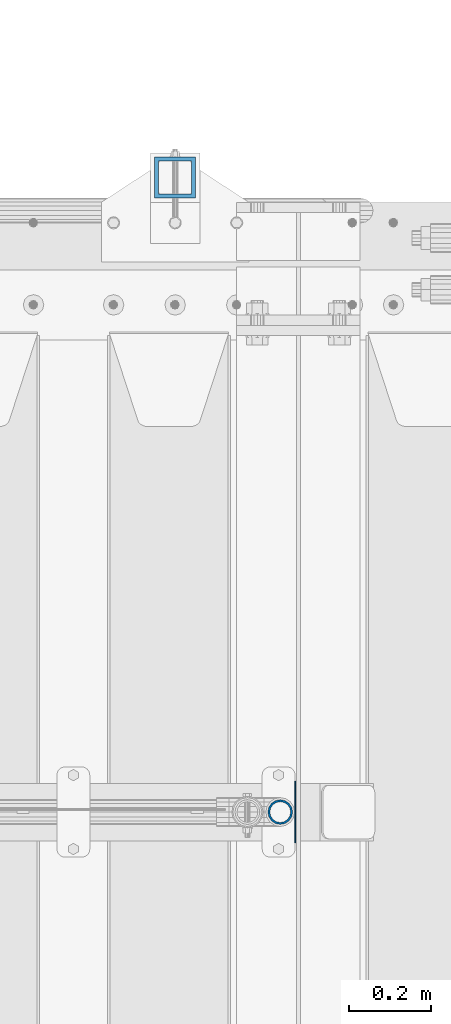
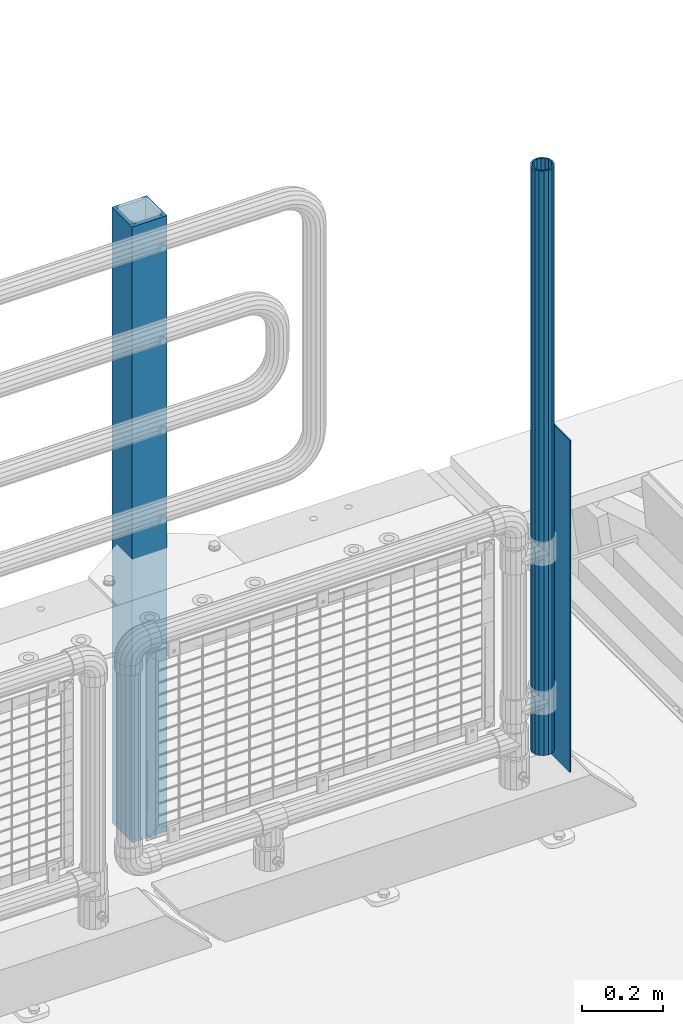
# One storey, part 66 of 247: 3 columns.
"""IFC2X3 building model written with IfcOpenShell, lengths in millimetres."""

from ifc_helpers import new_model, si_unit, frame, origin_with_axes, place, context, subcontext, project, spatial, faceted_brep, material, type_object, element, save


model = new_model("IFC2X3")

# Units and contexts
model_context = context("Model", 3, precision=1e-05, world=origin_with_axes())
body_context = subcontext(model_context, "Body", "Model", "MODEL_VIEW")
ifc_project = project(units=[si_unit("LENGTHUNIT", "METRE", prefix="MILLI"), si_unit("AREAUNIT", "SQUARE_METRE"), si_unit("VOLUMEUNIT", "CUBIC_METRE"), si_unit("MASSUNIT", "GRAM", prefix="KILO"), si_unit("TIMEUNIT", "SECOND"), si_unit("PLANEANGLEUNIT", "RADIAN"), si_unit("SOLIDANGLEUNIT", "STERADIAN"), si_unit("THERMODYNAMICTEMPERATUREUNIT", "DEGREE_CELSIUS"), si_unit("LUMINOUSINTENSITYUNIT", "LUMEN")], contexts=[model_context])

# Site, building, storey
site_placement = place(None, origin_with_axes())
site = spatial("IfcSite", under=ifc_project, at=site_placement, CompositionType="ELEMENT")
building_placement = place(site_placement, origin_with_axes())
building = spatial("IfcBuilding", under=site, at=building_placement, Name="Standard", CompositionType="ELEMENT")
storey_placement = place(building_placement, origin_with_axes())
storey = spatial("IfcBuildingStorey", under=building, at=storey_placement, Name="Undefined", CompositionType="ELEMENT", Elevation=0.0)

# Columns
ifc_material_1 = material(Name="Misc_Undefined")
column_type_1 = type_object("IfcColumnType", PredefinedType="NOTDEFINED")
column_1_placement = place(storey_placement, frame((16301.0, 7664.5, 238.02), z_axis=(-1.0, 0.0, 0.0), x_axis=(0.0, 0.0, 1.0)))
element("IfcColumn", 1, at=column_1_placement, inside=storey, type_object=column_type_1, material=ifc_material_1, context=body_context, shape_type="Brep", body=[
    faceted_brep([(0.0, -25.3500000000004, 0.0), (0.0, -23.4203461491616, 9.70102501045585), (1761.98, -23.4203461491616, 9.70102501045506), (1761.98, -25.3500000000004, 0.0), (0.0, -17.9251569030794, 17.9251569030785), (1761.98, -17.9251569030794, 17.925156903079), (0.0, -9.70102501045494, 23.4203461491616), (1761.98, -9.70102501045494, 23.4203461491611), (0.0, 0.0, 25.3500000000004), (1761.98, 0.0, 25.35), (0.0, 9.70102501045494, 23.4203461491616), (1761.98, 9.70102501045494, 23.4203461491611), (0.0, 17.9251569030794, 17.9251569030785), (1761.98, 17.9251569030794, 17.925156903079), (0.0, 23.4203461491616, 9.70102501045585), (1761.98, 23.4203461491616, 9.70102501045506), (0.0, 25.3500000000004, 0.0), (1761.98, 25.3500000000004, 0.0), (0.0, 23.4203461491616, -9.70102501045585), (1761.98, 23.4203461491616, -9.70102501045506), (0.0, 17.9251569030794, -17.9251569030785), (1761.98, 17.9251569030794, -17.925156903079), (0.0, 9.70102501045494, -23.4203461491616), (1761.98, 9.70102501045494, -23.4203461491611), (0.0, 0.0, -25.3500000000004), (1761.98, 0.0, -25.35), (0.0, -9.70102501045494, -23.4203461491616), (1761.98, -9.70102501045494, -23.4203461491611), (0.0, -17.9251569030794, -17.9251569030785), (1761.98, -17.9251569030794, -17.925156903079), (0.0, -23.4203461491616, -9.70102501045585), (1761.98, -23.4203461491616, -9.70102501045506), (0.0, -30.1499999999996, 0.0), (0.0, -27.8549679052148, -11.5379054858076), (1761.98, -27.8549679052148, -11.5379054858075), (1761.98, -30.1499999999996, 0.0), (0.0, -21.3192694527743, -21.3192694527752), (1761.98, -21.3192694527743, -21.3192694527744), (0.0, -11.5379054858076, -27.8549679052157), (1761.98, -11.5379054858076, -27.8549679052153), (0.0, 0.0, -30.1499999999996), (1761.98, 0.0, -30.15), (0.0, 11.5379054858076, -27.8549679052157), (1761.98, 11.5379054858076, -27.8549679052153), (0.0, 21.3192694527743, -21.3192694527752), (1761.98, 21.3192694527743, -21.3192694527744), (0.0, 27.8549679052157, -11.5379054858076), (1761.98, 27.8549679052157, -11.5379054858074), (0.0, 30.1499999999996, 0.0), (1761.98, 30.1499999999996, 0.0), (0.0, 27.8549679052157, 11.5379054858076), (1761.98, 27.8549679052157, 11.5379054858074), (0.0, 21.3192694527743, 21.3192694527752), (1761.98, 21.3192694527743, 21.3192694527744), (0.0, 11.5379054858076, 27.8549679052157), (1761.98, 11.5379054858076, 27.8549679052153), (0.0, 0.0, 30.1499999999996), (1761.98, 0.0, 30.15), (0.0, -11.5379054858076, 27.8549679052157), (1761.98, -11.5379054858076, 27.8549679052153), (0.0, -21.3192694527743, 21.3192694527752), (1761.98, -21.3192694527743, 21.3192694527744), (0.0, -27.8549679052157, 11.5379054858076), (1761.98, -27.8549679052157, 11.5379054858074)], [[[0, 1, 2, 3]], [[1, 4, 5, 2]], [[4, 6, 7, 5]], [[6, 8, 9, 7]], [[8, 10, 11, 9]], [[10, 12, 13, 11]], [[12, 14, 15, 13]], [[14, 16, 17, 15]], [[16, 18, 19, 17]], [[18, 20, 21, 19]], [[20, 22, 23, 21]], [[22, 24, 25, 23]], [[24, 26, 27, 25]], [[26, 28, 29, 27]], [[28, 30, 31, 29]], [[30, 0, 3, 31]], [[32, 33, 34, 35]], [[33, 36, 37, 34]], [[36, 38, 39, 37]], [[38, 40, 41, 39]], [[40, 42, 43, 41]], [[42, 44, 45, 43]], [[44, 46, 47, 45]], [[46, 48, 49, 47]], [[48, 50, 51, 49]], [[50, 52, 53, 51]], [[52, 54, 55, 53]], [[54, 56, 57, 55]], [[56, 58, 59, 57]], [[58, 60, 61, 59]], [[60, 62, 63, 61]], [[62, 32, 35, 63]], [[37, 39, 41, 43, 45, 47, 49, 51, 53, 55, 57, 59, 61, 63, 35, 34], [5, 7, 9, 11, 13, 15, 17, 19, 21, 23, 25, 27, 29, 31, 3, 2]], [[62, 60, 58, 56, 54, 52, 50, 48, 46, 44, 42, 40, 38, 36, 33, 32], [30, 28, 26, 24, 22, 20, 18, 16, 14, 12, 10, 8, 6, 4, 1, 0]]]),
])
ifc_material_2 = material()
column_type_2 = type_object("IfcColumnType", PredefinedType="NOTDEFINED")
column_2_placement = place(storey_placement, frame((16045.0000000001, 9210.00000000021, -844.999999999998), z_axis=(0.0, -0.999999999999548, -9.5100000000016e-07), x_axis=(0.0, 0.0, 1.0)))
element("IfcColumn", 2, at=column_2_placement, inside=storey, type_object=column_type_2, material=ifc_material_2, context=body_context, shape_type="Brep", body=[
    faceted_brep([(0.0, 40.0, -40.0), (0.0, -40.0, -40.0), (1855.0, -40.0, -40.0), (1855.0, 40.0, -40.0), (0.0, -40.0, 40.0), (1855.0, -40.0, 40.0), (0.0, 40.0, 40.0), (1855.0, 40.0, 40.0), (0.0, 50.0, -50.0), (0.0, 50.0, 50.0), (1855.0, 50.0, 50.0), (1855.0, 50.0, -50.0), (0.0, -50.0, 50.0), (1855.0, -50.0, 50.0), (0.0, -50.0, -50.0), (1855.0, -50.0, -50.0)], [[[0, 1, 2, 3]], [[1, 4, 5, 2]], [[4, 6, 7, 5]], [[6, 0, 3, 7]], [[8, 9, 10, 11]], [[9, 12, 13, 10]], [[12, 14, 15, 13]], [[14, 8, 11, 15]], [[13, 15, 11, 10], [5, 7, 3, 2]], [[14, 12, 9, 8], [6, 4, 1, 0]]]),
])
column_type_3 = type_object("IfcColumnType", PredefinedType="NOTDEFINED")
column_3_placement = place(storey_placement, frame((16337.5, 7664.5, 200.0), z_axis=(0.0, 1.0, 0.0), x_axis=(0.0, 0.0, 1.0)))
element("IfcColumn", 3, at=column_3_placement, inside=storey, type_object=column_type_3, material=ifc_material_1, context=body_context, shape_type="Brep", body=[
    faceted_brep([(0.0, 1.5, -75.0), (0.0, 1.5, 75.0), (1000.0, 1.5, 75.0), (1000.0, 1.5, -75.0), (0.0, -1.5, 75.0), (1000.0, -1.5, 75.0), (0.0, -1.5, -75.0), (1000.0, -1.5, -75.0)], [[[0, 1, 2, 3]], [[1, 4, 5, 2]], [[4, 6, 7, 5]], [[6, 0, 3, 7]], [[5, 7, 3, 2]], [[6, 4, 1, 0]]]),
])

save(model, "model.ifc")
